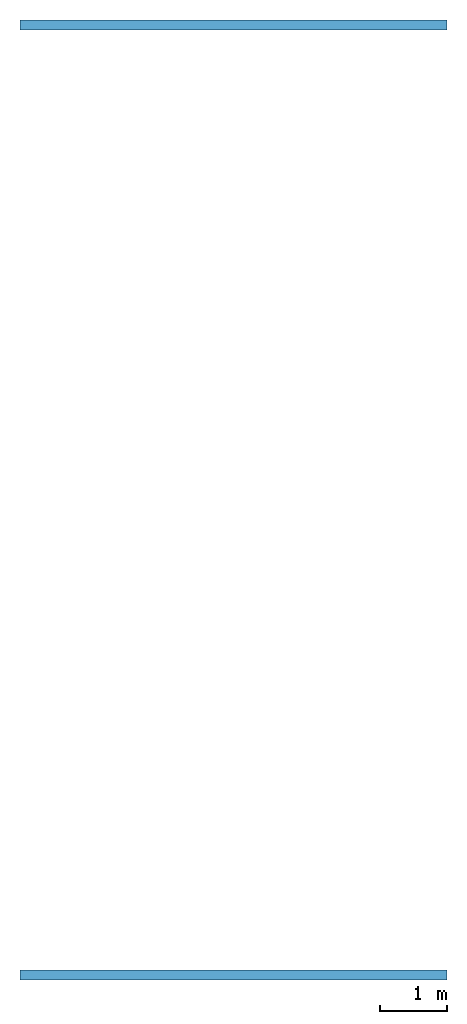
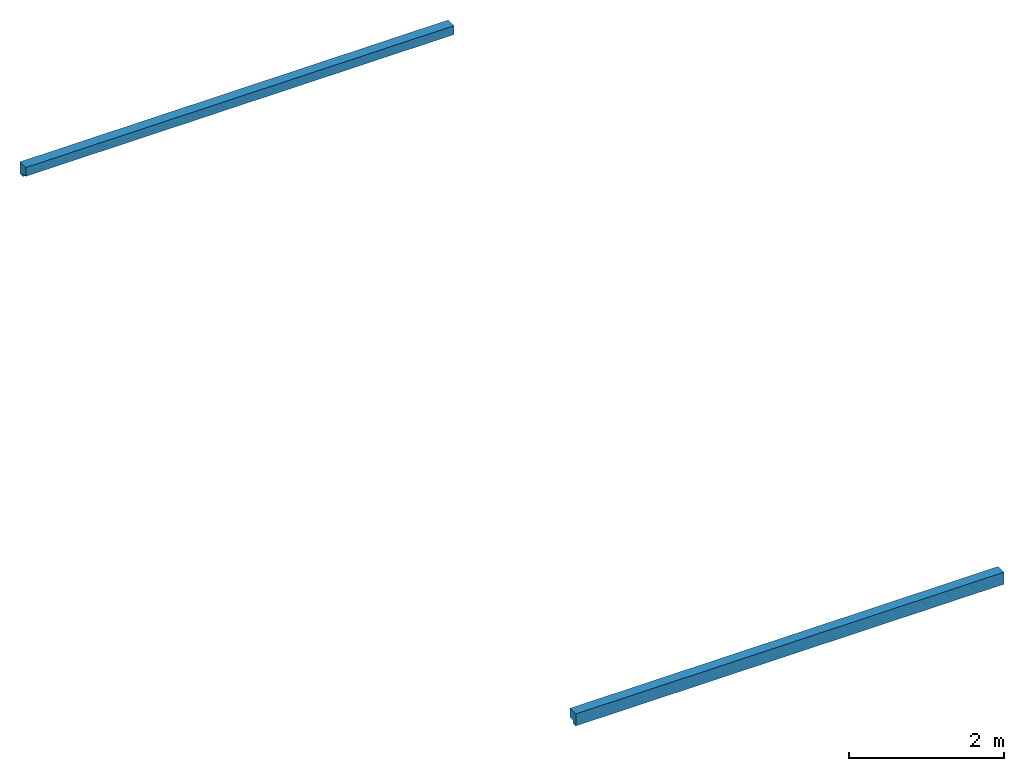
# One storey: 2 walls.
"""IFC2X3 building model written with IfcOpenShell, lengths in millimetres."""

from ifc_helpers import new_model, entity, si_unit, converted_unit, derived_unit, direction, frame, frame_2d, origin, place, context, subcontext, project, spatial, polyline, rectangle, extrude, clip, bounded_halfspace, material, layer, layer_set, layer_usage, type_object, element, save


model = new_model("IFC2X3")

# Units and contexts
model_context = context("Model", 3, precision=0.01, world=origin(), true_north=direction((6.12303176911189e-17, 1.0)))
body_context = subcontext(model_context, "Body", "Model", "MODEL_VIEW")
ifc_project = project(units=[si_unit("LENGTHUNIT", "METRE", prefix="MILLI"), si_unit("AREAUNIT", "SQUARE_METRE"), si_unit("VOLUMEUNIT", "CUBIC_METRE"), converted_unit("PLANEANGLEUNIT", "DEGREE", entity("IfcRatioMeasure", 0.0174532925199433), si_unit("PLANEANGLEUNIT", "RADIAN"), dimensions=[0, 0, 0, 0, 0, 0, 0]), si_unit("MASSUNIT", "GRAM", prefix="KILO"), derived_unit("MASSDENSITYUNIT", [(si_unit("MASSUNIT", "GRAM", prefix="KILO"), 1), (si_unit("LENGTHUNIT", "METRE"), -3)]), si_unit("TIMEUNIT", "SECOND"), si_unit("FREQUENCYUNIT", "HERTZ"), si_unit("THERMODYNAMICTEMPERATUREUNIT", "DEGREE_CELSIUS"), derived_unit("THERMALTRANSMITTANCEUNIT", [(si_unit("MASSUNIT", "GRAM", prefix="KILO"), 1), (si_unit("THERMODYNAMICTEMPERATUREUNIT", "KELVIN"), -1), (si_unit("TIMEUNIT", "SECOND"), -3)]), derived_unit("VOLUMETRICFLOWRATEUNIT", [(si_unit("LENGTHUNIT", "METRE"), 3), (si_unit("TIMEUNIT", "SECOND"), -1)]), si_unit("ELECTRICCURRENTUNIT", "AMPERE"), si_unit("ELECTRICVOLTAGEUNIT", "VOLT"), si_unit("POWERUNIT", "WATT"), si_unit("FORCEUNIT", "NEWTON", prefix="KILO"), si_unit("ILLUMINANCEUNIT", "LUX"), si_unit("LUMINOUSFLUXUNIT", "LUMEN"), si_unit("LUMINOUSINTENSITYUNIT", "CANDELA"), derived_unit("USERDEFINED", [(si_unit("MASSUNIT", "GRAM", prefix="KILO"), -1), (si_unit("LENGTHUNIT", "METRE"), -2), (si_unit("TIMEUNIT", "SECOND"), 3), (si_unit("LUMINOUSFLUXUNIT", "LUMEN"), 1)]), derived_unit("LINEARVELOCITYUNIT", [(si_unit("LENGTHUNIT", "METRE"), 1), (si_unit("TIMEUNIT", "SECOND"), -1)]), si_unit("PRESSUREUNIT", "PASCAL"), derived_unit("USERDEFINED", [(si_unit("LENGTHUNIT", "METRE"), -2), (si_unit("MASSUNIT", "GRAM", prefix="KILO"), 1), (si_unit("TIMEUNIT", "SECOND"), -2)])], contexts=[model_context])

# Site, building, storey
site_placement = place(None, origin())
site = spatial("IfcSite", under=ifc_project, at=site_placement, CompositionType="ELEMENT")
building_placement = place(site_placement, origin())
building = spatial("IfcBuilding", under=site, at=building_placement, CompositionType="ELEMENT")
storey_placement = place(building_placement, frame((0.0, 0.0, 4000.0)))
storey = spatial("IfcBuildingStorey", under=building, at=storey_placement, Name="01 Level", CompositionType="ELEMENT", Elevation=4000.0)

# Walls
ifc_material = material(Name="04_XPS PLUS 30 SF")
ifc_layer = layer(ifc_material, 150.0)
ifc_layer_set = layer_set([ifc_layer], Name="Basic Wall:00")
ifc_layer_usage_1 = layer_usage(ifc_layer_set, "AXIS2", "POSITIVE", -75.0)
wall_type = type_object("IfcWallType", Name="Basic Wall:00", PredefinedType="STANDARD", material=ifc_layer_set)
wall_1_placement = place(storey_placement, frame((28203.4900708518, -61711.23958514, -190.0), z_axis=(0.0, 0.0, 1.0), x_axis=(-1.0, 0.0, 0.0)))
element("IfcWallStandardCase", 1, at=wall_1_placement, inside=storey, type_object=wall_type, material=ifc_layer_usage_1, Name="Basic Wall:00", ObjectType="Basic Wall:00", context=body_context, shape_type="Clipping", body=[
    clip(clip(extrude(rectangle(XDim=6400.0, YDim=150.000000000001, at=frame_2d((3200.0, 2.03215222427389e-12), x_axis=(-1.0, 0.0))), origin(), (0.0, 0.0, 1.0), 189.999999999999), bounded_halfspace(frame((6400.0, 0.0, 50.0)), True, frame((6400.0, 0.0, 50.0)), polyline([(0.0, 0.0), (0.0, 75.0), (-6400.0, 75.0), (-6400.0, 0.0), (0.0, 0.0)]))), bounded_halfspace(frame((0.0, 0.0, 50.0), z_axis=(0.0, -1.0, 0.0), x_axis=(0.0, 0.0, 1.0)), True, frame((0.0, 0.0, 50.0), z_axis=(0.0, -1.0, 0.0), x_axis=(0.0, 0.0, 1.0)), polyline([(0.0, 0.0), (-50.0, 0.0), (-50.0, -6400.0), (0.0, -6400.0), (0.0, 0.0)]))),
])
ifc_layer_usage_2 = layer_usage(ifc_layer_set, "AXIS2", "NEGATIVE", 75.0)
wall_2_placement = place(storey_placement, frame((28203.4900708518, -75951.2395851399, -190.0), z_axis=(0.0, 0.0, 1.0), x_axis=(-1.0, 0.0, 0.0)))
element("IfcWallStandardCase", 2, at=wall_2_placement, inside=storey, type_object=wall_type, material=ifc_layer_usage_2, Name="Basic Wall:00", ObjectType="Basic Wall:00", context=body_context, shape_type="Clipping", body=[
    clip(clip(extrude(rectangle(XDim=6400.0, YDim=150.000000000001, at=frame_2d((3200.0, 0.0), x_axis=(-1.0, 0.0))), origin(), (0.0, 0.0, 1.0), 189.999999999999), bounded_halfspace(frame((0.0, 0.0, 50.0)), True, frame((0.0, 0.0, 50.0)), polyline([(0.0, 0.0), (0.0, -75.0), (6400.0, -75.0), (6400.0, 0.0), (0.0, 0.0)]))), bounded_halfspace(frame((6400.0, 0.0, 50.0), z_axis=(0.0, 1.0, 0.0), x_axis=(0.0, 0.0, 1.0)), True, frame((6400.0, 0.0, 50.0), z_axis=(0.0, 1.0, 0.0), x_axis=(0.0, 0.0, 1.0)), polyline([(0.0, 0.0), (-50.0, 0.0), (-50.0, -6400.0), (0.0, -6400.0), (0.0, 0.0)]))),
])

save(model, "model.ifc")
